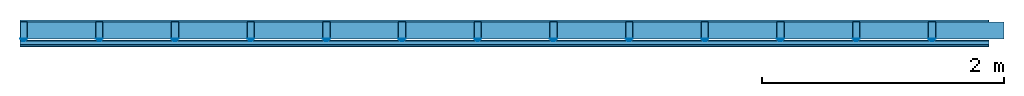
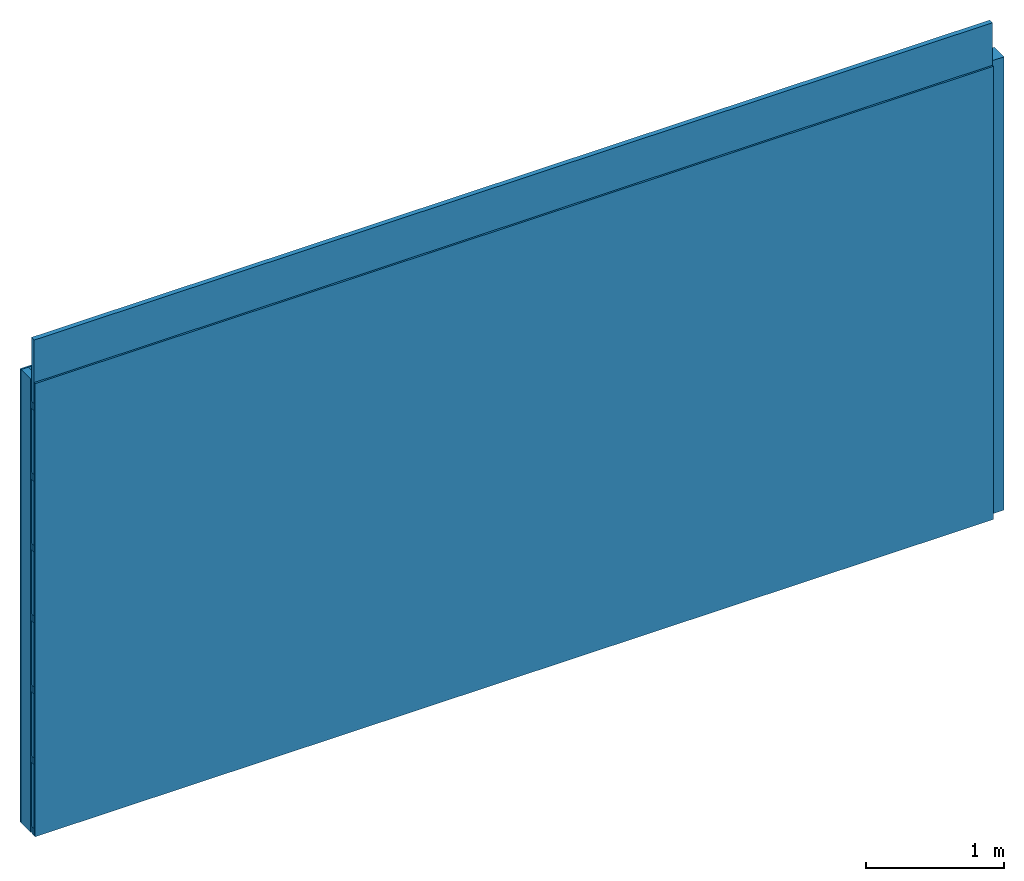
# One storey: 5 members, 2 plates, 1 element without a shape of its own.
"""IFC4 building model written with IfcOpenShell, lengths in metres."""

from ifc_helpers import new_model, si_unit, derived_unit, direction, frame, frame_2d, origin, origin_with_axes, place, context, project, spatial, polyline, rectangle, outline, extrude, material, layer, layer_set, type_object, element, aggregate, save


model = new_model("IFC4")

# Units and contexts
plan_context = context("Plan", 3, precision=1e-05, world=origin(), true_north=direction((0.0, 1.0)))
model_context = context("Model", 3, precision=1e-05, world=origin(), true_north=direction((0.0, 1.0)))
ifc_project = project(units=[si_unit("LENGTHUNIT", "METRE"), derived_unit("SOUNDPRESSUREUNIT", [(si_unit("PRESSUREUNIT", "PASCAL", prefix="MICRO"), 0)]), si_unit("ENERGYUNIT", "JOULE", prefix="MEGA"), si_unit("MASSUNIT", "GRAM", prefix="KILO"), derived_unit("THERMALTRANSMITTANCEUNIT", [(si_unit("POWERUNIT", "WATT"), 1), (si_unit("AREAUNIT", "SQUARE_METRE"), -1), (si_unit("THERMODYNAMICTEMPERATUREUNIT", "KELVIN"), -1)]), derived_unit("AREADENSITYUNIT", [(si_unit("MASSUNIT", "GRAM", prefix="KILO"), 1), (si_unit("AREAUNIT", "SQUARE_METRE"), -1)]), derived_unit("USERDEFINED", [(si_unit("ENERGYUNIT", "JOULE", prefix="MEGA"), 1), (si_unit("AREAUNIT", "SQUARE_METRE"), -1)])], contexts=[plan_context, model_context])

# Site, building, storey
site = spatial("IfcSite", under=ifc_project)
building_placement = place(None, origin())
building = spatial("IfcBuilding", under=site, at=building_placement)
storey_placement = place(building_placement, origin())
storey = spatial("IfcBuildingStorey", under=building, at=storey_placement)

# Wall, members, plates
ifc_material_1 = material(Name="Glued joints")
ifc_layer_1 = layer(ifc_material_1, 0.0, Name="Surface")
ifc_material_2 = material(Category="03.007")
ifc_layer_2 = layer(ifc_material_2, 0.015, Name="1st layer")
ifc_material_3 = material(Name="of the art")
ifc_layer_3 = layer(ifc_material_3, 0.0, Name="Bond")
ifc_layer_4 = layer(None, 0.14, Name="Support")
ifc_material_4 = material(Name="no composite action")
ifc_layer_5 = layer(ifc_material_4, 0.0, Name="Bond")
ifc_layer_6 = layer(None, 0.02, Name="Coupling")
ifc_layer_7 = layer(None, 0.03, Name="Battens / profiles")
ifc_layer_8 = layer(ifc_material_2, 0.015, Name="Covering 1st layer")
ifc_layer_9 = layer(ifc_material_1, 0.0, Name="Surface")
ifc_layer_set = layer_set([ifc_layer_1, ifc_layer_2, ifc_layer_3, ifc_layer_4, ifc_layer_5, ifc_layer_6, ifc_layer_7, ifc_layer_8, ifc_layer_9])
wall_type = type_object("IfcWallType", Name="C0098", PredefinedType="NOTDEFINED", material=ifc_layer_set)
wall_placement = place(None, frame((0.0, 0.0, 0.0), z_axis=(0.0, -1.0, 0.0), x_axis=(1.0, 0.0, 0.0)))
wall = element("IfcWall", 1, at=wall_placement, inside=storey, type_object=wall_type, material=ifc_layer_set, Name="Wall #1")
ifc_material_5 = material()
member_1_placement = place(wall_placement, origin())
member_1 = element("IfcMember", 2, at=member_1_placement, material=ifc_material_5, Name="Support", context=plan_context, shape_type="SweptSolid", body=[
    extrude(rectangle(XDim=0.06, YDim=0.14, at=frame_2d((0.03, 0.07), x_axis=(1.0, 0.0))), frame((0.0, 4.0, 0.015), z_axis=(0.0, -1.0, 0.0), x_axis=(1.0, 0.0, 0.0)), (0.0, 0.0, 1.0), 4.0),
    extrude(rectangle(XDim=0.06, YDim=0.14, at=frame_2d((0.03, 0.07), x_axis=(1.0, 0.0))), frame((0.625, 4.0, 0.015), z_axis=(0.0, -1.0, 0.0), x_axis=(1.0, 0.0, 0.0)), (0.0, 0.0, 1.0), 4.0),
    extrude(rectangle(XDim=0.06, YDim=0.14, at=frame_2d((0.03, 0.07), x_axis=(1.0, 0.0))), frame((1.25, 4.0, 0.015), z_axis=(0.0, -1.0, 0.0), x_axis=(1.0, 0.0, 0.0)), (0.0, 0.0, 1.0), 4.0),
    extrude(rectangle(XDim=0.06, YDim=0.14, at=frame_2d((0.03, 0.07), x_axis=(1.0, 0.0))), frame((1.875, 4.0, 0.015), z_axis=(0.0, -1.0, 0.0), x_axis=(1.0, 0.0, 0.0)), (0.0, 0.0, 1.0), 4.0),
    extrude(rectangle(XDim=0.06, YDim=0.14, at=frame_2d((0.03, 0.07), x_axis=(1.0, 0.0))), frame((2.5, 4.0, 0.015), z_axis=(0.0, -1.0, 0.0), x_axis=(1.0, 0.0, 0.0)), (0.0, 0.0, 1.0), 4.0),
    extrude(rectangle(XDim=0.06, YDim=0.14, at=frame_2d((0.03, 0.07), x_axis=(1.0, 0.0))), frame((3.125, 4.0, 0.015), z_axis=(0.0, -1.0, 0.0), x_axis=(1.0, 0.0, 0.0)), (0.0, 0.0, 1.0), 4.0),
    extrude(rectangle(XDim=0.06, YDim=0.14, at=frame_2d((0.03, 0.07), x_axis=(1.0, 0.0))), frame((3.75, 4.0, 0.015), z_axis=(0.0, -1.0, 0.0), x_axis=(1.0, 0.0, 0.0)), (0.0, 0.0, 1.0), 4.0),
    extrude(rectangle(XDim=0.06, YDim=0.14, at=frame_2d((0.03, 0.07), x_axis=(1.0, 0.0))), frame((4.375, 4.0, 0.015), z_axis=(0.0, -1.0, 0.0), x_axis=(1.0, 0.0, 0.0)), (0.0, 0.0, 1.0), 4.0),
    extrude(rectangle(XDim=0.06, YDim=0.14, at=frame_2d((0.03, 0.07), x_axis=(1.0, 0.0))), frame((5.0, 4.0, 0.015), z_axis=(0.0, -1.0, 0.0), x_axis=(1.0, 0.0, 0.0)), (0.0, 0.0, 1.0), 4.0),
    extrude(rectangle(XDim=0.06, YDim=0.14, at=frame_2d((0.03, 0.07), x_axis=(1.0, 0.0))), frame((5.625, 4.0, 0.015), z_axis=(0.0, -1.0, 0.0), x_axis=(1.0, 0.0, 0.0)), (0.0, 0.0, 1.0), 4.0),
    extrude(rectangle(XDim=0.06, YDim=0.14, at=frame_2d((0.03, 0.07), x_axis=(1.0, 0.0))), frame((6.25, 4.0, 0.015), z_axis=(0.0, -1.0, 0.0), x_axis=(1.0, 0.0, 0.0)), (0.0, 0.0, 1.0), 4.0),
    extrude(rectangle(XDim=0.06, YDim=0.14, at=frame_2d((0.03, 0.07), x_axis=(1.0, 0.0))), frame((6.875, 4.0, 0.015), z_axis=(0.0, -1.0, 0.0), x_axis=(1.0, 0.0, 0.0)), (0.0, 0.0, 1.0), 4.0),
    extrude(rectangle(XDim=0.06, YDim=0.14, at=frame_2d((0.03, 0.07), x_axis=(1.0, 0.0))), frame((7.5, 4.0, 0.015), z_axis=(0.0, -1.0, 0.0), x_axis=(1.0, 0.0, 0.0)), (0.0, 0.0, 1.0), 4.0),
])
ifc_material_6 = material()
member_2_placement = place(wall_placement, origin())
member_2 = element("IfcMember", 3, at=member_2_placement, material=ifc_material_6, Name="Cavity", context=plan_context, shape_type="SweptSolid", body=[
    extrude(rectangle(XDim=0.565, YDim=0.14, at=frame_2d((0.2825, 0.07), x_axis=(1.0, 0.0))), frame((0.06, 4.0, 0.015), z_axis=(0.0, -1.0, 0.0), x_axis=(1.0, 0.0, 0.0)), (0.0, 0.0, 1.0), 4.0),
    extrude(rectangle(XDim=0.565, YDim=0.14, at=frame_2d((0.2825, 0.07), x_axis=(1.0, 0.0))), frame((0.685, 4.0, 0.015), z_axis=(0.0, -1.0, 0.0), x_axis=(1.0, 0.0, 0.0)), (0.0, 0.0, 1.0), 4.0),
    extrude(rectangle(XDim=0.565, YDim=0.14, at=frame_2d((0.2825, 0.07), x_axis=(1.0, 0.0))), frame((1.31, 4.0, 0.015), z_axis=(0.0, -1.0, 0.0), x_axis=(1.0, 0.0, 0.0)), (0.0, 0.0, 1.0), 4.0),
    extrude(rectangle(XDim=0.565, YDim=0.14, at=frame_2d((0.2825, 0.07), x_axis=(1.0, 0.0))), frame((1.935, 4.0, 0.015), z_axis=(0.0, -1.0, 0.0), x_axis=(1.0, 0.0, 0.0)), (0.0, 0.0, 1.0), 4.0),
    extrude(rectangle(XDim=0.565, YDim=0.14, at=frame_2d((0.2825, 0.07), x_axis=(1.0, 0.0))), frame((2.56, 4.0, 0.015), z_axis=(0.0, -1.0, 0.0), x_axis=(1.0, 0.0, 0.0)), (0.0, 0.0, 1.0), 4.0),
    extrude(rectangle(XDim=0.565, YDim=0.14, at=frame_2d((0.2825, 0.07), x_axis=(1.0, 0.0))), frame((3.185, 4.0, 0.015), z_axis=(0.0, -1.0, 0.0), x_axis=(1.0, 0.0, 0.0)), (0.0, 0.0, 1.0), 4.0),
    extrude(rectangle(XDim=0.565, YDim=0.14, at=frame_2d((0.2825, 0.07), x_axis=(1.0, 0.0))), frame((3.81, 4.0, 0.015), z_axis=(0.0, -1.0, 0.0), x_axis=(1.0, 0.0, 0.0)), (0.0, 0.0, 1.0), 4.0),
    extrude(rectangle(XDim=0.565, YDim=0.14, at=frame_2d((0.2825, 0.07), x_axis=(1.0, 0.0))), frame((4.435, 4.0, 0.015), z_axis=(0.0, -1.0, 0.0), x_axis=(1.0, 0.0, 0.0)), (0.0, 0.0, 1.0), 4.0),
    extrude(rectangle(XDim=0.565, YDim=0.14, at=frame_2d((0.2825, 0.07), x_axis=(1.0, 0.0))), frame((5.06, 4.0, 0.015), z_axis=(0.0, -1.0, 0.0), x_axis=(1.0, 0.0, 0.0)), (0.0, 0.0, 1.0), 4.0),
    extrude(rectangle(XDim=0.565, YDim=0.14, at=frame_2d((0.2825, 0.07), x_axis=(1.0, 0.0))), frame((5.685, 4.0, 0.015), z_axis=(0.0, -1.0, 0.0), x_axis=(1.0, 0.0, 0.0)), (0.0, 0.0, 1.0), 4.0),
    extrude(rectangle(XDim=0.565, YDim=0.14, at=frame_2d((0.2825, 0.07), x_axis=(1.0, 0.0))), frame((6.31, 4.0, 0.015), z_axis=(0.0, -1.0, 0.0), x_axis=(1.0, 0.0, 0.0)), (0.0, 0.0, 1.0), 4.0),
    extrude(rectangle(XDim=0.565, YDim=0.14, at=frame_2d((0.2825, 0.07), x_axis=(1.0, 0.0))), frame((6.935, 4.0, 0.015), z_axis=(0.0, -1.0, 0.0), x_axis=(1.0, 0.0, 0.0)), (0.0, 0.0, 1.0), 4.0),
    extrude(rectangle(XDim=0.565, YDim=0.14, at=frame_2d((0.2825, 0.07), x_axis=(1.0, 0.0))), frame((7.56, 4.0, 0.015), z_axis=(0.0, -1.0, 0.0), x_axis=(1.0, 0.0, 0.0)), (0.0, 0.0, 1.0), 4.0),
])
ifc_material_7 = material()
member_3_placement = place(wall_placement, origin())
member_3 = element("IfcMember", 4, at=member_3_placement, material=ifc_material_7, Name="Coupling", context=plan_context, shape_type="SweptSolid", body=[
    extrude(outline(polyline([(0.0, 0.0), (0.06, 0.0), (0.04, 0.02), (0.02, 0.02), (0.0, 0.0)])), frame((0.0, 4.0, 0.155), z_axis=(0.0, -1.0, 0.0), x_axis=(1.0, 0.0, 0.0)), (0.0, 0.0, 1.0), 4.0),
    extrude(outline(polyline([(0.0, 0.0), (0.06, 0.0), (0.04, 0.02), (0.02, 0.02), (0.0, 0.0)])), frame((0.625, 4.0, 0.155), z_axis=(0.0, -1.0, 0.0), x_axis=(1.0, 0.0, 0.0)), (0.0, 0.0, 1.0), 4.0),
    extrude(outline(polyline([(0.0, 0.0), (0.06, 0.0), (0.04, 0.02), (0.02, 0.02), (0.0, 0.0)])), frame((1.25, 4.0, 0.155), z_axis=(0.0, -1.0, 0.0), x_axis=(1.0, 0.0, 0.0)), (0.0, 0.0, 1.0), 4.0),
    extrude(outline(polyline([(0.0, 0.0), (0.06, 0.0), (0.04, 0.02), (0.02, 0.02), (0.0, 0.0)])), frame((1.875, 4.0, 0.155), z_axis=(0.0, -1.0, 0.0), x_axis=(1.0, 0.0, 0.0)), (0.0, 0.0, 1.0), 4.0),
    extrude(outline(polyline([(0.0, 0.0), (0.06, 0.0), (0.04, 0.02), (0.02, 0.02), (0.0, 0.0)])), frame((2.5, 4.0, 0.155), z_axis=(0.0, -1.0, 0.0), x_axis=(1.0, 0.0, 0.0)), (0.0, 0.0, 1.0), 4.0),
    extrude(outline(polyline([(0.0, 0.0), (0.06, 0.0), (0.04, 0.02), (0.02, 0.02), (0.0, 0.0)])), frame((3.125, 4.0, 0.155), z_axis=(0.0, -1.0, 0.0), x_axis=(1.0, 0.0, 0.0)), (0.0, 0.0, 1.0), 4.0),
    extrude(outline(polyline([(0.0, 0.0), (0.06, 0.0), (0.04, 0.02), (0.02, 0.02), (0.0, 0.0)])), frame((3.75, 4.0, 0.155), z_axis=(0.0, -1.0, 0.0), x_axis=(1.0, 0.0, 0.0)), (0.0, 0.0, 1.0), 4.0),
    extrude(outline(polyline([(0.0, 0.0), (0.06, 0.0), (0.04, 0.02), (0.02, 0.02), (0.0, 0.0)])), frame((4.375, 4.0, 0.155), z_axis=(0.0, -1.0, 0.0), x_axis=(1.0, 0.0, 0.0)), (0.0, 0.0, 1.0), 4.0),
    extrude(outline(polyline([(0.0, 0.0), (0.06, 0.0), (0.04, 0.02), (0.02, 0.02), (0.0, 0.0)])), frame((5.0, 4.0, 0.155), z_axis=(0.0, -1.0, 0.0), x_axis=(1.0, 0.0, 0.0)), (0.0, 0.0, 1.0), 4.0),
    extrude(outline(polyline([(0.0, 0.0), (0.06, 0.0), (0.04, 0.02), (0.02, 0.02), (0.0, 0.0)])), frame((5.625, 4.0, 0.155), z_axis=(0.0, -1.0, 0.0), x_axis=(1.0, 0.0, 0.0)), (0.0, 0.0, 1.0), 4.0),
    extrude(outline(polyline([(0.0, 0.0), (0.06, 0.0), (0.04, 0.02), (0.02, 0.02), (0.0, 0.0)])), frame((6.25, 4.0, 0.155), z_axis=(0.0, -1.0, 0.0), x_axis=(1.0, 0.0, 0.0)), (0.0, 0.0, 1.0), 4.0),
    extrude(outline(polyline([(0.0, 0.0), (0.06, 0.0), (0.04, 0.02), (0.02, 0.02), (0.0, 0.0)])), frame((6.875, 4.0, 0.155), z_axis=(0.0, -1.0, 0.0), x_axis=(1.0, 0.0, 0.0)), (0.0, 0.0, 1.0), 4.0),
    extrude(outline(polyline([(0.0, 0.0), (0.06, 0.0), (0.04, 0.02), (0.02, 0.02), (0.0, 0.0)])), frame((7.5, 4.0, 0.155), z_axis=(0.0, -1.0, 0.0), x_axis=(1.0, 0.0, 0.0)), (0.0, 0.0, 1.0), 4.0),
])
ifc_material_8 = material()
member_4_placement = place(wall_placement, origin())
member_4 = element("IfcMember", 5, at=member_4_placement, material=ifc_material_8, Name="Battens / profiles", context=plan_context, shape_type="SweptSolid", body=[
    extrude(rectangle(XDim=0.06, YDim=0.03, at=frame_2d((0.03, 0.015), x_axis=(1.0, 0.0))), frame((0.0, 0.0, 0.175), z_axis=(1.0, 0.0, 0.0), x_axis=(0.0, 1.0, 0.0)), (0.0, 0.0, 1.0), 8.0),
    extrude(rectangle(XDim=0.06, YDim=0.03, at=frame_2d((0.03, 0.015), x_axis=(1.0, 0.0))), frame((0.0, 0.625, 0.175), z_axis=(1.0, 0.0, 0.0), x_axis=(0.0, 1.0, 0.0)), (0.0, 0.0, 1.0), 8.0),
    extrude(rectangle(XDim=0.06, YDim=0.03, at=frame_2d((0.03, 0.015), x_axis=(1.0, 0.0))), frame((0.0, 1.25, 0.175), z_axis=(1.0, 0.0, 0.0), x_axis=(0.0, 1.0, 0.0)), (0.0, 0.0, 1.0), 8.0),
    extrude(rectangle(XDim=0.06, YDim=0.03, at=frame_2d((0.03, 0.015), x_axis=(1.0, 0.0))), frame((0.0, 1.875, 0.175), z_axis=(1.0, 0.0, 0.0), x_axis=(0.0, 1.0, 0.0)), (0.0, 0.0, 1.0), 8.0),
    extrude(rectangle(XDim=0.06, YDim=0.03, at=frame_2d((0.03, 0.015), x_axis=(1.0, 0.0))), frame((0.0, 2.5, 0.175), z_axis=(1.0, 0.0, 0.0), x_axis=(0.0, 1.0, 0.0)), (0.0, 0.0, 1.0), 8.0),
    extrude(rectangle(XDim=0.06, YDim=0.03, at=frame_2d((0.03, 0.015), x_axis=(1.0, 0.0))), frame((0.0, 3.125, 0.175), z_axis=(1.0, 0.0, 0.0), x_axis=(0.0, 1.0, 0.0)), (0.0, 0.0, 1.0), 8.0),
    extrude(rectangle(XDim=0.06, YDim=0.03, at=frame_2d((0.03, 0.015), x_axis=(1.0, 0.0))), frame((0.0, 3.75, 0.175), z_axis=(1.0, 0.0, 0.0), x_axis=(0.0, 1.0, 0.0)), (0.0, 0.0, 1.0), 8.0),
])
member_5_placement = place(wall_placement, origin())
member_5 = element("IfcMember", 6, at=member_5_placement, material=ifc_material_6, Name="Cavity", context=plan_context, shape_type="SweptSolid", body=[
    extrude(rectangle(XDim=0.565, YDim=0.04, at=frame_2d((0.2825, 0.02), x_axis=(1.0, 0.0))), frame((0.0, 0.06, 0.165), z_axis=(1.0, 0.0, 0.0), x_axis=(0.0, 1.0, 0.0)), (0.0, 0.0, 1.0), 8.0),
    extrude(rectangle(XDim=0.565, YDim=0.04, at=frame_2d((0.2825, 0.02), x_axis=(1.0, 0.0))), frame((0.0, 0.685, 0.165), z_axis=(1.0, 0.0, 0.0), x_axis=(0.0, 1.0, 0.0)), (0.0, 0.0, 1.0), 8.0),
    extrude(rectangle(XDim=0.565, YDim=0.04, at=frame_2d((0.2825, 0.02), x_axis=(1.0, 0.0))), frame((0.0, 1.31, 0.165), z_axis=(1.0, 0.0, 0.0), x_axis=(0.0, 1.0, 0.0)), (0.0, 0.0, 1.0), 8.0),
    extrude(rectangle(XDim=0.565, YDim=0.04, at=frame_2d((0.2825, 0.02), x_axis=(1.0, 0.0))), frame((0.0, 1.935, 0.165), z_axis=(1.0, 0.0, 0.0), x_axis=(0.0, 1.0, 0.0)), (0.0, 0.0, 1.0), 8.0),
    extrude(rectangle(XDim=0.565, YDim=0.04, at=frame_2d((0.2825, 0.02), x_axis=(1.0, 0.0))), frame((0.0, 2.56, 0.165), z_axis=(1.0, 0.0, 0.0), x_axis=(0.0, 1.0, 0.0)), (0.0, 0.0, 1.0), 8.0),
    extrude(rectangle(XDim=0.565, YDim=0.04, at=frame_2d((0.2825, 0.02), x_axis=(1.0, 0.0))), frame((0.0, 3.185, 0.165), z_axis=(1.0, 0.0, 0.0), x_axis=(0.0, 1.0, 0.0)), (0.0, 0.0, 1.0), 8.0),
    extrude(rectangle(XDim=0.565, YDim=0.04, at=frame_2d((0.2825, 0.02), x_axis=(1.0, 0.0))), frame((0.0, 3.81, 0.165), z_axis=(1.0, 0.0, 0.0), x_axis=(0.0, 1.0, 0.0)), (0.0, 0.0, 1.0), 8.0),
])
plate_1_placement = place(wall_placement, origin())
plate_1 = element("IfcPlate", 7, at=plate_1_placement, material=ifc_material_2, Name="1st layer", context=plan_context, shape_type="SweptSolid", body=[
    extrude(rectangle(XDim=8.0, YDim=4.0, at=frame_2d((4.0, 2.0), x_axis=(1.0, 0.0))), origin_with_axes(), (0.0, 0.0, 1.0), 0.015),
])
plate_2_placement = place(wall_placement, origin())
plate_2 = element("IfcPlate", 8, at=plate_2_placement, material=ifc_material_2, Name="Covering 1st layer", context=plan_context, shape_type="SweptSolid", body=[
    extrude(rectangle(XDim=8.0, YDim=4.0, at=frame_2d((4.0, 2.0), x_axis=(1.0, 0.0))), frame((0.0, 0.0, 0.205), z_axis=(0.0, 0.0, 1.0), x_axis=(1.0, 0.0, 0.0)), (0.0, 0.0, 1.0), 0.015),
])
aggregate(wall, [plate_1, member_1, member_2, member_3, member_4, member_5, plate_2])

save(model, "model.ifc")
